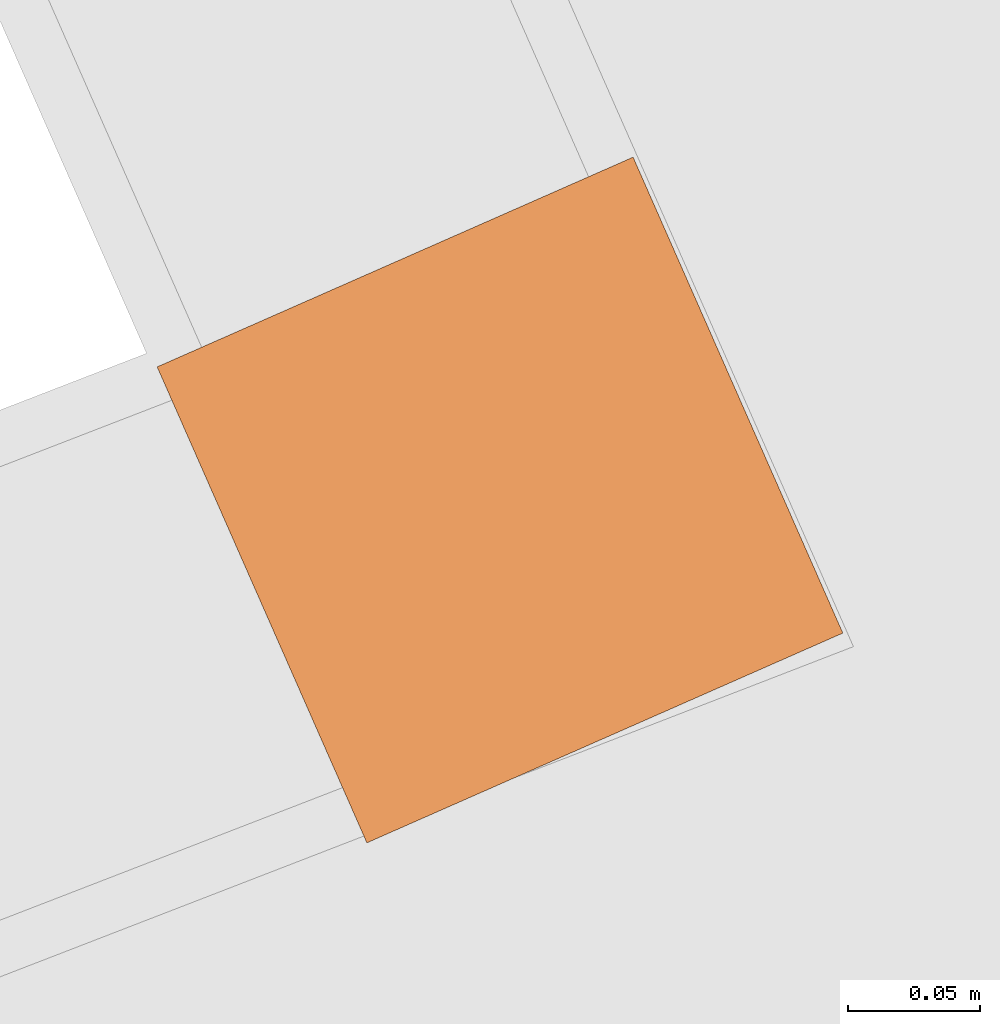
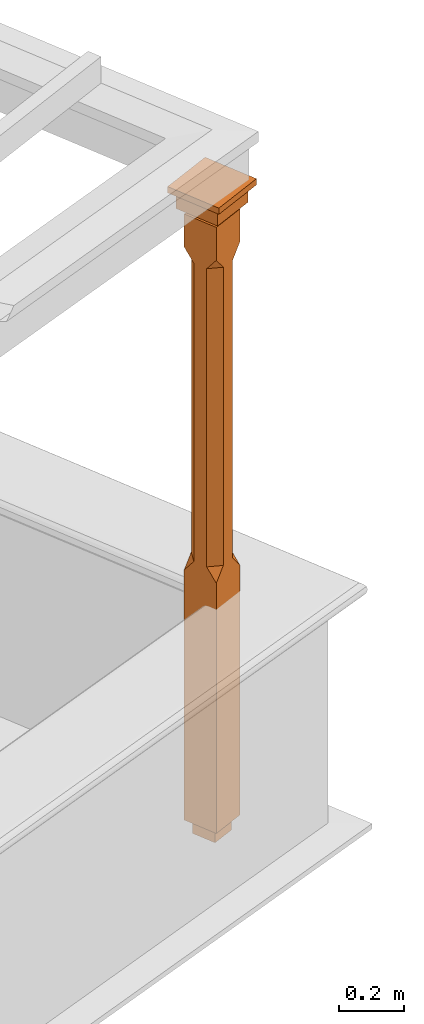
# One storey, part 11 of 11: 1 proxy.
"""IFC2X3 building model written with IfcOpenShell, lengths in metres."""

import ifcopenshell
import ifcopenshell.guid

model = None  # the IFC model being written
_history = None  # IfcOwnerHistory: only IFC2X3 demands one
_inside = {}  # id of a spatial element -> (the spatial element, [elements in it])
_under = {}  # id of a project, library or spatial element -> (it, [spatial elements below it])
_declared = {}  # id of a project -> (the project, [libraries it declares])
_typed = {}  # id of a type object -> (the type object, [elements of that type])
_made_of = {}  # id of a material, layer set ... -> (it, [elements and type objects made of it])


def new_model(schema):
    """Start an empty IFC model of exactly this schema.

    Asked for "IFC4X3", IfcOpenShell would pick the latest addendum, in which some entities
    have other attributes; the version numbers below select the first issue.
    IFC2X3 requires an IfcOwnerHistory on every rooted entity: one is made here for all.
    """
    global model, _history
    if schema == "IFC4X3":
        model = ifcopenshell.file(schema_version=(4, 3, 0, 0))
    else:
        model = ifcopenshell.file(schema=schema)
    _inside.clear()
    _under.clear()
    _declared.clear()
    _typed.clear()
    _made_of.clear()
    _history = None
    if model.schema == "IFC2X3":
        org = make("IfcOrganization", Name="unknown")
        user = make(
            "IfcPersonAndOrganization",
            ThePerson=make("IfcPerson", FamilyName="unknown"),
            TheOrganization=org,
        )
        app = make(
            "IfcApplication",
            ApplicationDeveloper=org,
            Version="unknown",
            ApplicationFullName="unknown",
            ApplicationIdentifier="unknown",
        )
        _history = make(
            "IfcOwnerHistory",
            OwningUser=user,
            OwningApplication=app,
            ChangeAction="ADDED",
            CreationDate=0,
        )
    return model


def make(cls, **values):
    """One entity of the class cls with the attributes given. An attribute that is None is left unset."""
    return model.create_entity(
        cls, **{name: value for name, value in values.items() if value is not None}
    )


def rooted(cls, **values):
    """An entity with a GlobalId (a new one), such as an element, a storey or a relation."""
    return make(cls, GlobalId=ifcopenshell.guid.new(), OwnerHistory=_history, **values)


def si_unit(unit_type, name, prefix=None):
    """IfcSIUnit, for example si_unit("LENGTHUNIT", "METRE", prefix="MILLI")."""
    return make("IfcSIUnit", UnitType=unit_type, Prefix=prefix, Name=name)


def assignment(units):
    """IfcUnitAssignment: the units of a project."""
    return None if units is None else make("IfcUnitAssignment", Units=units)


def point(xyz):
    """IfcCartesianPoint."""
    return None if xyz is None else make("IfcCartesianPoint", Coordinates=xyz)


def direction(xyz):
    """IfcDirection."""
    return None if xyz is None else make("IfcDirection", DirectionRatios=xyz)


def frame(location, z_axis=None, x_axis=None):
    """IfcAxis2Placement3D, a coordinate frame: its origin and axes. An axis left out is left unset."""
    return make(
        "IfcAxis2Placement3D",
        Location=point(location),
        Axis=direction(z_axis),
        RefDirection=direction(x_axis),
    )


def origin():
    """The frame at (0, 0, 0) with its axes left unset."""
    return frame((0.0, 0.0, 0.0))


def place(relative_to, where):
    """IfcLocalPlacement: puts the frame where relative to a parent placement (None: the world)."""
    return make(
        "IfcLocalPlacement", PlacementRelTo=relative_to, RelativePlacement=where
    )


def context(
    kind, dimensions, precision=None, world=None, true_north=None, identifier=None
):
    """IfcGeometricRepresentationContext, for example the 3D "Model" context."""
    return make(
        "IfcGeometricRepresentationContext",
        ContextIdentifier=identifier,
        ContextType=kind,
        CoordinateSpaceDimension=dimensions,
        Precision=precision,
        WorldCoordinateSystem=world,
        TrueNorth=true_north,
    )


def subcontext(parent, identifier, kind, view, scale=None):
    """IfcGeometricRepresentationSubContext, for example "Body" below "Model"."""
    return make(
        "IfcGeometricRepresentationSubContext",
        ContextIdentifier=identifier,
        ContextType=kind,
        ParentContext=parent,
        TargetScale=scale,
        TargetView=view,
    )


def project(units=None, contexts=None):
    """IfcProject with its units and contexts."""
    return rooted(
        "IfcProject",
        Name="project",
        RepresentationContexts=contexts,
        UnitsInContext=assignment(units),
    )


def spatial(cls, under=None, at=None, **own):
    """A site, building, storey or space (cls), placed at a placement, below another one or the project."""
    s = rooted(cls, ObjectPlacement=at, **own)
    if under is not None:
        _under.setdefault(under.id(), (under, []))[1].append(s)
    return s


def faces_of(points, faces, orient=None, outer=None):
    """IfcFace entities. A face is a list of loops; a loop is a list of indices into points, from 0.

    orient and outer hold one flag for each loop. By default every Orientation is true, the
    first loop of a face is its IfcFaceOuterBound and the others are IfcFaceBound.
    """
    made = []
    for i, loops in enumerate(faces):
        bounds = []
        for j, loop in enumerate(loops):
            is_outer = j == 0 if outer is None else outer[i][j]
            bounds.append(
                make(
                    "IfcFaceOuterBound" if is_outer else "IfcFaceBound",
                    Bound=make("IfcPolyLoop", Polygon=[points[k] for k in loop]),
                    Orientation=True if orient is None else orient[i][j],
                )
            )
        made.append(make("IfcFace", Bounds=bounds))
    return made


def faceted_brep(points, faces, orient=None, outer=None, voids=None):
    """IfcFacetedBrep: a solid bounded by flat faces; with voids (closed shells), ...WithVoids."""
    shared = [point(p) for p in points]
    hull = make("IfcClosedShell", CfsFaces=faces_of(shared, faces, orient, outer))
    if voids is None:
        return make("IfcFacetedBrep", Outer=hull)
    return make(
        "IfcFacetedBrepWithVoids",
        Outer=hull,
        Voids=[
            make(cls, CfsFaces=faces_of(shared, fs, o, b)) for cls, fs, o, b in voids
        ],
    )


def shape(context_of_items, identifier, shape_type, items):
    """IfcShapeRepresentation: the items that make up one representation, for example the "Body"."""
    return make(
        "IfcShapeRepresentation",
        ContextOfItems=context_of_items,
        RepresentationIdentifier=identifier,
        RepresentationType=shape_type,
        Items=items,
    )


def made_of(thing, what):
    """Note that an element or type object is made of a material, layer set ...; save() writes the relation."""
    if what is not None:
        _made_of.setdefault(what.id(), (what, []))[1].append(thing)
    return thing


def element(
    cls,
    number,
    at=None,
    inside=None,
    cuts=None,
    type_object=None,
    material=None,
    context=None,
    identifier="Body",
    shape_type=None,
    held_by="IfcProductDefinitionShape",
    body=None,
    shapes=None,
    **own,
):
    """One element of the class cls, such as IfcWall. Its Tag is "e" and its number.

    at: its placement. inside: the storey or other place that contains it. cuts: it is an
    opening in that element (IfcRelVoidsElement). A single representation is given by context,
    identifier, shape_type and body (its items); several are given by shapes. held_by: the class
    of the entity that holds the representations. save() writes the other relations.
    """
    e = rooted(cls, Tag="e%d" % number, ObjectPlacement=at, **own)
    if body is not None:
        shapes = [shape(context, identifier, shape_type, body)]
    if shapes is not None:
        e.Representation = make(held_by, Representations=shapes)
    if inside is not None:
        _inside.setdefault(inside.id(), (inside, []))[1].append(e)
    if cuts is not None:
        rooted(
            "IfcRelVoidsElement", RelatingBuildingElement=cuts, RelatedOpeningElement=e
        )
    if type_object is not None:
        _typed.setdefault(type_object.id(), (type_object, []))[1].append(e)
    return made_of(e, material)


def aggregate(whole, parts):
    """IfcRelAggregates: a whole, such as a stair, and the parts it consists of."""
    return rooted("IfcRelAggregates", RelatingObject=whole, RelatedObjects=parts)


def save(model, path):
    """Write the relations noted so far, then the file.

    IfcRelAggregates (storeys below a building ...), IfcRelContainedInSpatialStructure (elements
    in a storey), IfcRelDefinesByType, IfcRelAssociatesMaterial and IfcRelDeclares: one each for
    every whole, place, type object, material and project.
    """
    for whole, parts in _under.values():
        aggregate(whole, parts)
    for where, things in _inside.values():
        rooted(
            "IfcRelContainedInSpatialStructure",
            RelatedElements=things,
            RelatingStructure=where,
        )
    for kind, things in _typed.values():
        rooted("IfcRelDefinesByType", RelatedObjects=things, RelatingType=kind)
    for what, things in _made_of.values():
        rooted("IfcRelAssociatesMaterial", RelatedObjects=things, RelatingMaterial=what)
    for by, libraries in _declared.values():
        rooted("IfcRelDeclares", RelatingContext=by, RelatedDefinitions=libraries)
    model.write(path)


model = new_model("IFC2X3")

# Units and contexts
model_context = context("Model", 3, world=origin())
body_context = subcontext(model_context, "Body", "Model", "MODEL_VIEW")
ifc_project = project(units=[si_unit("PLANEANGLEUNIT", "RADIAN"), si_unit("MASSUNIT", "GRAM", prefix="KILO"), si_unit("FORCEUNIT", "NEWTON", prefix="KILO"), si_unit("LENGTHUNIT", "METRE")], contexts=[model_context])

# Site, building, storey
site_placement = place(None, origin())
site = spatial("IfcSite", under=ifc_project, at=site_placement, CompositionType="ELEMENT")
building_placement = place(None, origin())
building = spatial("IfcBuilding", under=site, at=building_placement, Name="Building plot-5", CompositionType="ELEMENT")
storey_placement = place(None, frame((0.0, 0.0, 7.6)))
storey = spatial("IfcBuildingStorey", under=building, at=storey_placement, Name="Floor 1", CompositionType="ELEMENT", Elevation=7.6)

# Proxy
proxy_placement = place(storey_placement, frame((66.09972502398, 57.2028144348295, 0.0), z_axis=(0.0, 0.0, 1.0), x_axis=(-0.403249700330841, 0.915089984199962, 0.0)))
element("IfcBuildingElementProxy", 1, at=proxy_placement, inside=storey, Name="pergola post", CompositionType="ELEMENT", context=body_context, shape_type="Brep", held_by="IfcProductRepresentation", body=[
    faceted_brep([(0.0246, -0.0615, 2.17), (0.0615, -0.0246, 2.17), (0.0615, -0.0615, 2.216667), (0.0615, -0.0246, 1.044444), (0.0246, -0.0615, 1.044444), (0.0615, 0.0246, 2.17), (0.0615, 0.0615, 2.216667), (-0.0246, -0.0615, 2.17), (-0.0615, -0.0615, 2.216667), (-0.0246, -0.0615, 1.044444), (0.0615, -0.0615, 0.997778), (0.0615, 0.0246, 1.044444), (0.0246, 0.0615, 2.17), (0.0615, 0.0615, 2.341111), (0.0615, -0.0615, 2.341111), (-0.0615, -0.0615, 2.341111), (-0.0615, -0.0246, 2.17), (-0.0615, -0.0246, 1.044444), (-0.0615, -0.0615, 0.997778), (0.0615, 0.0615, 0.997778), (0.0246, 0.0615, 1.044444), (-0.0246, 0.0615, 2.17), (-0.0615, 0.0615, 2.216667), (0.04305, 0.04305, 2.341111), (0.04305, -0.04305, 2.341111), (-0.0615, 0.0615, 2.341111), (-0.04305, -0.04305, 2.341111), (-0.0615, 0.0246, 2.17), (-0.0615, 0.0246, 1.044444), (0.0615, -0.0615, 0.053333), (-0.0615, -0.0615, 0.053333), (0.0615, 0.0615, 0.053333), (-0.0246, 0.0615, 1.044444), (-0.04305, 0.04305, 2.341111), (0.04305, 0.04305, 2.364444), (0.04305, -0.04305, 2.364444), (-0.04305, -0.04305, 2.364444), (-0.0615, 0.0615, 0.997778), (-0.0615, 0.0615, 0.053333), (-0.04305, -0.04305, 0.053333), (0.04305, -0.04305, 0.053333), (0.04305, 0.04305, 0.053333), (-0.04305, 0.04305, 2.364444), (0.07995, 0.07995, 2.364444), (0.07995, -0.07995, 2.364444), (-0.07995, -0.07995, 2.364444), (-0.04305, 0.04305, 0.053333), (-0.04305, -0.04305, 0.0), (0.04305, -0.04305, 0.0), (0.04305, 0.04305, 0.0), (-0.07995, 0.07995, 2.364444), (0.07995, 0.07995, 2.426667), (0.07995, -0.07995, 2.426667), (-0.07995, -0.07995, 2.426667), (-0.04305, 0.04305, 0.0), (-0.07995, 0.07995, 2.426667), (0.0984, 0.0984, 2.426667), (0.0984, -0.0984, 2.426667), (-0.0984, -0.0984, 2.426667), (-0.0984, 0.0984, 2.426667), (0.0984, 0.0984, 2.45), (0.0984, -0.0984, 2.45), (-0.0984, -0.0984, 2.45), (-0.0984, 0.0984, 2.45)], [[[0, 1, 2]], [[3, 1, 0, 4]], [[1, 5, 6, 2]], [[7, 0, 2, 8]], [[4, 0, 7, 9]], [[3, 4, 10]], [[1, 3, 11, 5]], [[5, 12, 6]], [[13, 14, 2, 6]], [[15, 8, 2, 14]], [[8, 16, 7]], [[9, 7, 16, 17]], [[9, 18, 10, 4]], [[3, 10, 19, 11]], [[20, 12, 5, 11]], [[21, 22, 6, 12]], [[14, 13, 23, 24]], [[13, 6, 22, 25]], [[25, 22, 8, 15]], [[26, 15, 14, 24]], [[16, 8, 22, 27]], [[27, 28, 17, 16]], [[17, 18, 9]], [[29, 10, 18, 30]], [[31, 19, 10, 29]], [[20, 11, 19]], [[12, 20, 32, 21]], [[21, 27, 22]], [[33, 23, 13, 25]], [[23, 34, 35, 24]], [[26, 33, 25, 15]], [[36, 26, 24, 35]], [[28, 27, 21, 32]], [[17, 28, 37, 18]], [[38, 30, 18, 37]], [[29, 30, 39, 40]], [[31, 38, 37, 19]], [[40, 41, 31, 29]], [[32, 20, 19, 37]], [[33, 42, 34, 23]], [[43, 44, 35, 34]], [[42, 33, 26, 36]], [[36, 35, 44, 45]], [[28, 32, 37]], [[46, 39, 30, 38]], [[39, 47, 48, 40]], [[46, 38, 31, 41]], [[49, 41, 40, 48]], [[43, 34, 42, 50]], [[43, 51, 52, 44]], [[45, 50, 42, 36]], [[53, 45, 44, 52]], [[46, 54, 47, 39]], [[54, 46, 41, 49]], [[50, 55, 51, 43]], [[56, 57, 52, 51]], [[55, 50, 45, 53]], [[53, 52, 57, 58]], [[56, 51, 55, 59]], [[56, 60, 61, 57]], [[58, 59, 55, 53]], [[62, 58, 57, 61]], [[59, 63, 60, 56]], [[63, 62, 61, 60]], [[58, 62, 63, 59]], [[47, 54, 49, 48]]]),
])

save(model, "model.ifc")
